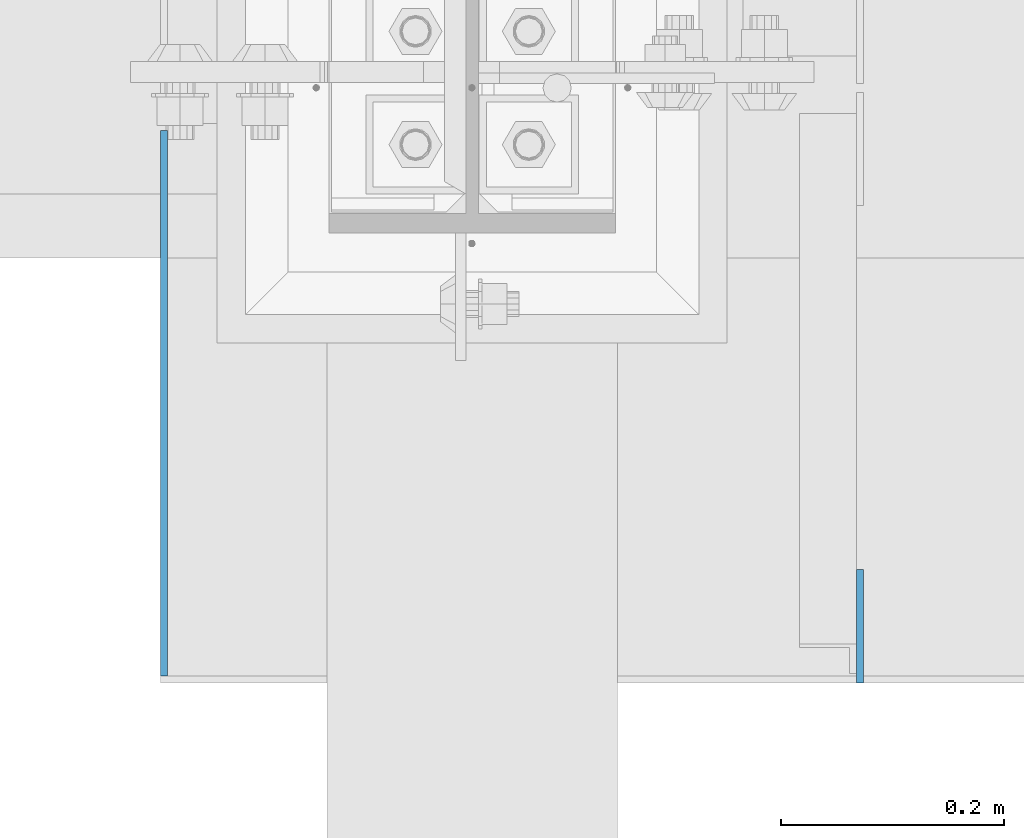
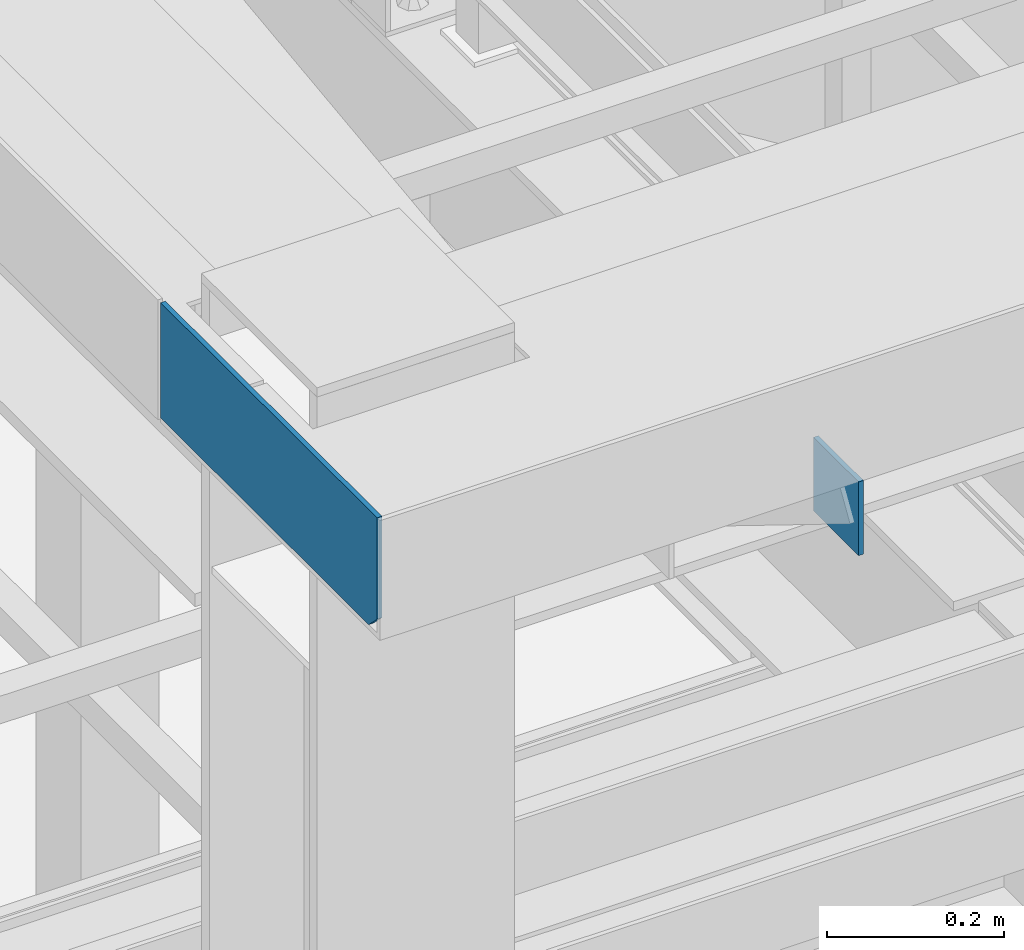
# One storey, part 3045 of 3843: 2 plates, 1 element without a shape of its own.
"""IFC2X3 building model written with IfcOpenShell, lengths in millimetres."""

from ifc_helpers import new_model, si_unit, frame, origin_with_axes, place, context, subcontext, project, spatial, faceted_brep, material, type_object, element, aggregate, save


model = new_model("IFC2X3")

# Units and contexts
model_context = context("Model", 3, precision=1e-05, world=origin_with_axes())
body_context = subcontext(model_context, "Body", "Model", "MODEL_VIEW")
ifc_project = project(units=[si_unit("LENGTHUNIT", "METRE", prefix="MILLI"), si_unit("AREAUNIT", "SQUARE_METRE"), si_unit("VOLUMEUNIT", "CUBIC_METRE"), si_unit("MASSUNIT", "GRAM", prefix="KILO"), si_unit("TIMEUNIT", "SECOND"), si_unit("PLANEANGLEUNIT", "RADIAN"), si_unit("SOLIDANGLEUNIT", "STERADIAN"), si_unit("THERMODYNAMICTEMPERATUREUNIT", "DEGREE_CELSIUS"), si_unit("LUMINOUSINTENSITYUNIT", "LUMEN")], contexts=[model_context])

# Site, building, storey
site_placement = place(None, origin_with_axes())
site = spatial("IfcSite", under=ifc_project, at=site_placement, CompositionType="ELEMENT")
building_placement = place(site_placement, origin_with_axes())
building = spatial("IfcBuilding", under=site, at=building_placement, Name="Undefined", CompositionType="ELEMENT")
storey_placement = place(building_placement, origin_with_axes())
storey = spatial("IfcBuildingStorey", under=building, at=storey_placement, Name="Undefined", CompositionType="ELEMENT", Elevation=0.0)

# Assembly, plates
assembly_placement = place(storey_placement, origin_with_axes())
assembly = element("IfcElementAssembly", 1, at=assembly_placement, inside=storey, Name="BEAM", AssemblyPlace="NOTDEFINED", PredefinedType="RIGID_FRAME")
ifc_material = material(Name="STEEL/A572-50")
plate_type_1 = type_object("IfcPlateType", PredefinedType="NOTDEFINED")
plate_1_placement = place(assembly_placement, frame((49344.2625, 14566.8999999151, 42468.7999999095), z_axis=(0.0, 0.0, -1.0), x_axis=(0.0, -1.0, 0.0)))
plate_1 = element("IfcPlate", 2, at=plate_1_placement, type_object=plate_type_1, material=ifc_material, Name="PLATE", context=body_context, shape_type="Brep", body=[
    faceted_brep([(0.0, -3.17499999999927, 0.0), (0.0, -3.17499999999927, 101.600000000006), (0.0, 3.17499999999927, 101.600000000006), (0.0, 3.17499999999927, 0.0), (101.6, -3.17500000000291, 101.599999999999), (101.6, 3.17500000000291, 101.599999999999), (101.600000000035, -3.17500000000291, -7.27595761418343e-12), (101.600000000035, 3.17500000000291, -7.27595761418343e-12)], [[[0, 1, 2, 3]], [[1, 4, 5, 2]], [[4, 6, 7, 5]], [[6, 0, 3, 7]], [[5, 7, 3, 2]], [[6, 4, 1, 0]]]),
])
plate_type_2 = type_object("IfcPlateType", PredefinedType="NOTDEFINED")
plate_2_placement = place(assembly_placement, frame((48720.3745, 14960.6, 42475.15), z_axis=(0.0, 0.0, 1.0), x_axis=(0.0, -1.0, 0.0)))
plate_2 = element("IfcPlate", 3, at=plate_2_placement, type_object=plate_type_2, material=ifc_material, Name="PLATE", context=body_context, shape_type="Brep", body=[
    faceted_brep([(0.0, -3.17499999999927, 0.0), (0.0, -3.17500000000291, 158.75), (0.0, 3.17500000000291, 158.75), (0.0, 3.17499999999927, 0.0), (488.949999999999, -3.17500000000291, 158.75), (488.949999999999, 3.17500000000291, 158.75), (488.949999999999, -3.17500000000291, 19.0499992370605), (488.949999999999, 3.17500000000291, 19.0499992370605), (469.900000762938, -3.17500000000291, 0.0), (469.900000762938, 3.17500000000291, 0.0)], [[[0, 1, 2, 3]], [[1, 4, 5, 2]], [[4, 6, 7, 5]], [[6, 8, 9, 7]], [[8, 0, 3, 9]], [[5, 7, 9, 3, 2]], [[8, 6, 4, 1, 0]]]),
])
aggregate(assembly, [plate_1, plate_2])

save(model, "model.ifc")
